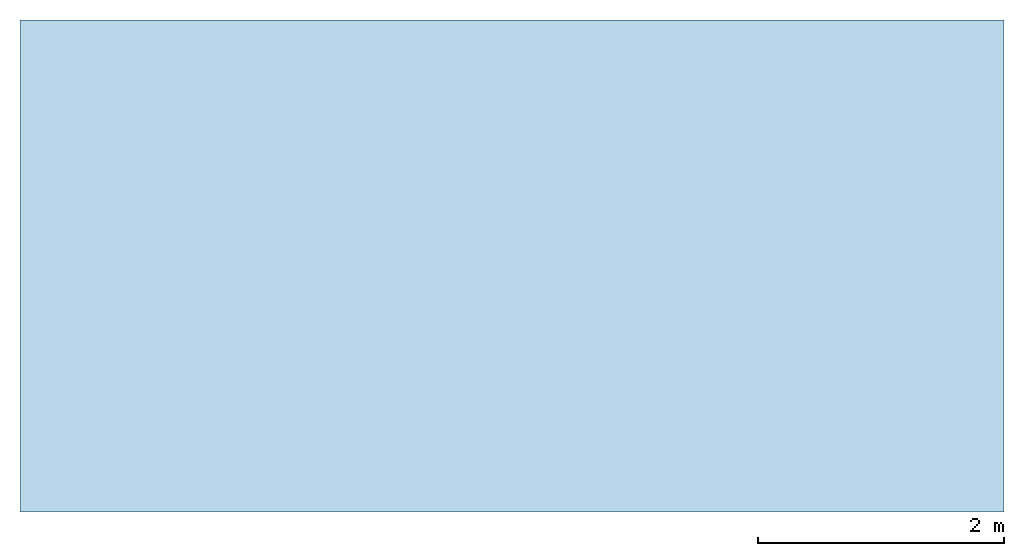
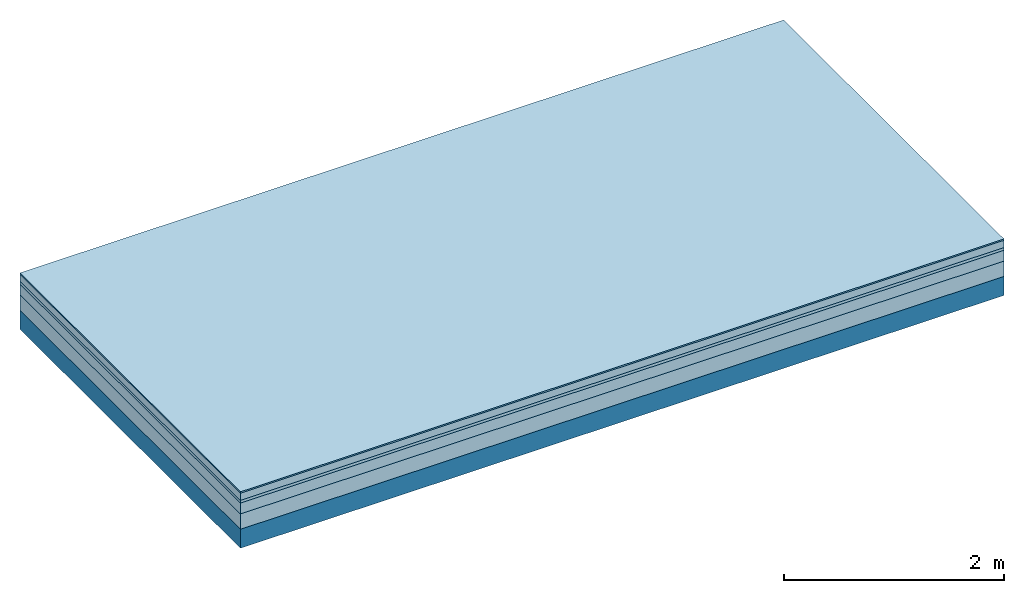
# One storey: 5 plates, 1 member, 1 element without a shape of its own.
"""IFC4 building model written with IfcOpenShell, lengths in metres."""

from ifc_helpers import new_model, si_unit, derived_unit, direction, frame, frame_2d, origin, origin_with_axes, place, context, project, spatial, rectangle, extrude, material, layer, layer_set, type_object, element, aggregate, save


model = new_model("IFC4")

# Units and contexts
plan_context = context("Plan", 3, precision=1e-05, world=origin(), true_north=direction((0.0, 1.0)))
model_context = context("Model", 3, precision=1e-05, world=origin(), true_north=direction((0.0, 1.0)))
ifc_project = project(units=[si_unit("LENGTHUNIT", "METRE"), derived_unit("SOUNDPRESSUREUNIT", [(si_unit("PRESSUREUNIT", "PASCAL", prefix="MICRO"), 0)]), si_unit("ENERGYUNIT", "JOULE", prefix="MEGA"), si_unit("MASSUNIT", "GRAM", prefix="KILO"), derived_unit("THERMALTRANSMITTANCEUNIT", [(si_unit("POWERUNIT", "WATT"), 1), (si_unit("AREAUNIT", "SQUARE_METRE"), -1), (si_unit("THERMODYNAMICTEMPERATUREUNIT", "KELVIN"), -1)]), derived_unit("AREADENSITYUNIT", [(si_unit("MASSUNIT", "GRAM", prefix="KILO"), 1), (si_unit("AREAUNIT", "SQUARE_METRE"), -1)]), derived_unit("USERDEFINED", [(si_unit("ENERGYUNIT", "JOULE", prefix="MEGA"), 1), (si_unit("AREAUNIT", "SQUARE_METRE"), -1)])], contexts=[plan_context, model_context])

# Site, building, storey
site = spatial("IfcSite", under=ifc_project)
building_placement = place(None, origin())
building = spatial("IfcBuilding", under=site, at=building_placement)
storey_placement = place(building_placement, origin())
storey = spatial("IfcBuildingStorey", under=building, at=storey_placement)

# Slab, member, plates
ifc_material_1 = material(Category="11.013")
ifc_layer_1 = layer(ifc_material_1, 0.015, Name="Flooring")
ifc_material_2 = material(Name="Cement screed", Category="04.006")
ifc_layer_2 = layer(ifc_material_2, 0.08, Name="On-material")
ifc_material_3 = material(Name="Wood fiber generic product", Category="10.009")
ifc_layer_3 = layer(ifc_material_3, 0.03, Name="Impact sound insulation")
ifc_material_4 = material(Name="Cement screed with EPS", Category="04.006")
ifc_layer_4 = layer(ifc_material_4, 0.12, Name="on Supporting structure")
ifc_material_5 = material(Category="01.002")
ifc_layer_5 = layer(ifc_material_5, 0.17, Name="Sub-floor")
ifc_material_6 = material(Name="Rigid, of the art")
ifc_layer_6 = layer(ifc_material_6, 0.0, Name="Bond")
ifc_layer_7 = layer(None, 0.21, Name="Supporting structure")
ifc_layer_set = layer_set([ifc_layer_1, ifc_layer_2, ifc_layer_3, ifc_layer_4, ifc_layer_5, ifc_layer_6, ifc_layer_7])
slab_type = type_object("IfcSlabType", Name="A2222", PredefinedType="NOTDEFINED", material=ifc_layer_set)
slab_placement = place(None, frame((0.0, 0.0, 0.0), z_axis=(0.0, 0.0, -1.0), x_axis=(1.0, 0.0, 0.0)))
slab = element("IfcSlab", 1, at=slab_placement, inside=storey, type_object=slab_type, material=ifc_layer_set, Name="Slab #1")
ifc_material_7 = material(Name="Solid timber panel")
member_placement = place(slab_placement, origin())
member = element("IfcMember", 2, at=member_placement, material=ifc_material_7, Name="Supporting structure", context=plan_context, shape_type="SweptSolid", body=[
    extrude(rectangle(XDim=1.0, YDim=0.21, at=frame_2d((0.5, 0.105), x_axis=(1.0, 0.0))), frame((0.0, 4.0, 0.415), z_axis=(0.0, -1.0, 0.0), x_axis=(1.0, 0.0, 0.0)), (0.0, 0.0, 1.0), 4.0),
    extrude(rectangle(XDim=1.0, YDim=0.21, at=frame_2d((0.5, 0.105), x_axis=(1.0, 0.0))), frame((1.0, 4.0, 0.415), z_axis=(0.0, -1.0, 0.0), x_axis=(1.0, 0.0, 0.0)), (0.0, 0.0, 1.0), 4.0),
    extrude(rectangle(XDim=1.0, YDim=0.21, at=frame_2d((0.5, 0.105), x_axis=(1.0, 0.0))), frame((2.0, 4.0, 0.415), z_axis=(0.0, -1.0, 0.0), x_axis=(1.0, 0.0, 0.0)), (0.0, 0.0, 1.0), 4.0),
    extrude(rectangle(XDim=1.0, YDim=0.21, at=frame_2d((0.5, 0.105), x_axis=(1.0, 0.0))), frame((3.0, 4.0, 0.415), z_axis=(0.0, -1.0, 0.0), x_axis=(1.0, 0.0, 0.0)), (0.0, 0.0, 1.0), 4.0),
    extrude(rectangle(XDim=1.0, YDim=0.21, at=frame_2d((0.5, 0.105), x_axis=(1.0, 0.0))), frame((4.0, 4.0, 0.415), z_axis=(0.0, -1.0, 0.0), x_axis=(1.0, 0.0, 0.0)), (0.0, 0.0, 1.0), 4.0),
    extrude(rectangle(XDim=1.0, YDim=0.21, at=frame_2d((0.5, 0.105), x_axis=(1.0, 0.0))), frame((5.0, 4.0, 0.415), z_axis=(0.0, -1.0, 0.0), x_axis=(1.0, 0.0, 0.0)), (0.0, 0.0, 1.0), 4.0),
    extrude(rectangle(XDim=1.0, YDim=0.21, at=frame_2d((0.5, 0.105), x_axis=(1.0, 0.0))), frame((6.0, 4.0, 0.415), z_axis=(0.0, -1.0, 0.0), x_axis=(1.0, 0.0, 0.0)), (0.0, 0.0, 1.0), 4.0),
    extrude(rectangle(XDim=1.0, YDim=0.21, at=frame_2d((0.5, 0.105), x_axis=(1.0, 0.0))), frame((7.0, 4.0, 0.415), z_axis=(0.0, -1.0, 0.0), x_axis=(1.0, 0.0, 0.0)), (0.0, 0.0, 1.0), 4.0),
])
plate_1_placement = place(slab_placement, origin())
plate_1 = element("IfcPlate", 3, at=plate_1_placement, material=ifc_material_1, Name="Flooring", context=plan_context, shape_type="SweptSolid", body=[
    extrude(rectangle(XDim=8.0, YDim=4.0, at=frame_2d((4.0, 2.0), x_axis=(1.0, 0.0))), origin_with_axes(), (0.0, 0.0, 1.0), 0.015),
])
plate_2_placement = place(slab_placement, origin())
plate_2 = element("IfcPlate", 4, at=plate_2_placement, material=ifc_material_2, Name="On-material", context=plan_context, shape_type="SweptSolid", body=[
    extrude(rectangle(XDim=8.0, YDim=4.0, at=frame_2d((4.0, 2.0), x_axis=(1.0, 0.0))), frame((0.0, 0.0, 0.015), z_axis=(0.0, 0.0, 1.0), x_axis=(1.0, 0.0, 0.0)), (0.0, 0.0, 1.0), 0.08),
])
plate_3_placement = place(slab_placement, origin())
plate_3 = element("IfcPlate", 5, at=plate_3_placement, material=ifc_material_3, Name="Impact sound insulation", context=plan_context, shape_type="SweptSolid", body=[
    extrude(rectangle(XDim=8.0, YDim=4.0, at=frame_2d((4.0, 2.0), x_axis=(1.0, 0.0))), frame((0.0, 0.0, 0.095), z_axis=(0.0, 0.0, 1.0), x_axis=(1.0, 0.0, 0.0)), (0.0, 0.0, 1.0), 0.03),
])
plate_4_placement = place(slab_placement, origin())
plate_4 = element("IfcPlate", 6, at=plate_4_placement, material=ifc_material_4, Name="on Supporting structure", context=plan_context, shape_type="SweptSolid", body=[
    extrude(rectangle(XDim=8.0, YDim=4.0, at=frame_2d((4.0, 2.0), x_axis=(1.0, 0.0))), frame((0.0, 0.0, 0.125), z_axis=(0.0, 0.0, 1.0), x_axis=(1.0, 0.0, 0.0)), (0.0, 0.0, 1.0), 0.12),
])
plate_5_placement = place(slab_placement, origin())
plate_5 = element("IfcPlate", 7, at=plate_5_placement, material=ifc_material_5, Name="Sub-floor", context=plan_context, shape_type="SweptSolid", body=[
    extrude(rectangle(XDim=8.0, YDim=4.0, at=frame_2d((4.0, 2.0), x_axis=(1.0, 0.0))), frame((0.0, 0.0, 0.245), z_axis=(0.0, 0.0, 1.0), x_axis=(1.0, 0.0, 0.0)), (0.0, 0.0, 1.0), 0.17),
])
aggregate(slab, [plate_1, plate_2, plate_3, plate_4, plate_5, member])

save(model, "model.ifc")
